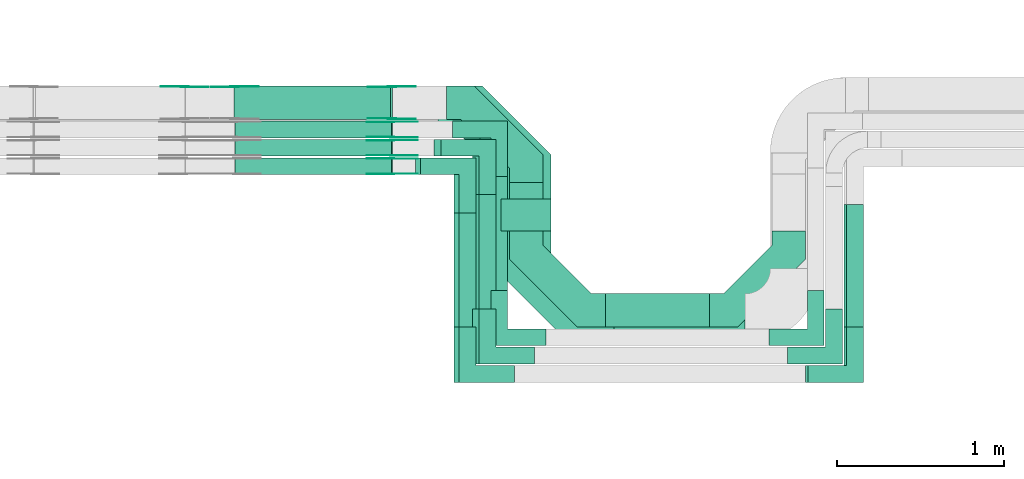
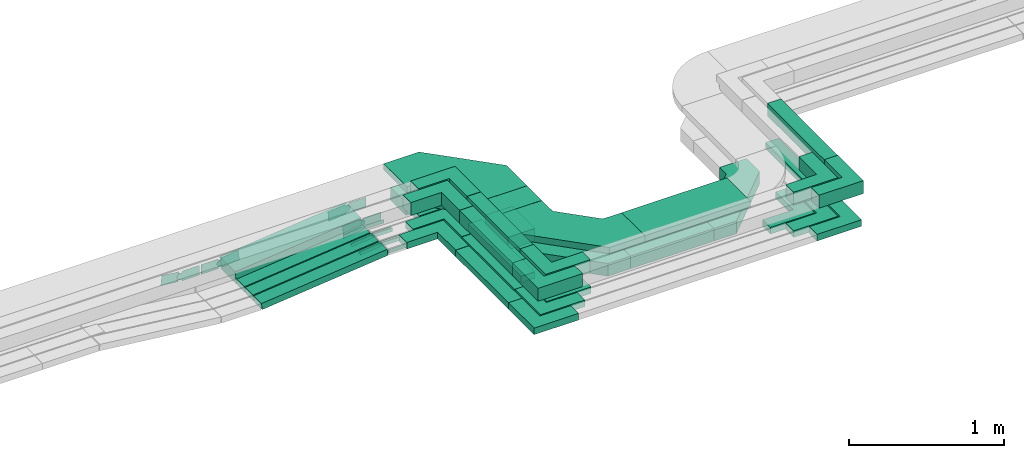
# One storey, part 19 of 32: 40 flow fittings, 15 flow segments.
"""IFC2X3 building model written with IfcOpenShell, lengths in millimetres."""

from ifc_helpers import new_model, entity, si_unit, converted_unit, derived_unit, direction, frame, frame_2d, origin, origin_2d_with_axis, place, context, subcontext, project, spatial, polyline, circle_curve, parameter, trimmed, segment, composite_curve, rectangle, outline, extrude, source, transform, mapped, material, type_object, type_shapes, element, save


model = new_model("IFC2X3")

# Units and contexts
model_context = context("Model", 3, precision=0.01, world=origin(), true_north=direction((6.12303176911189e-17, 1.0)))
body_context = subcontext(model_context, "Body", "Model", "MODEL_VIEW")
ifc_project = project(units=[si_unit("LENGTHUNIT", "METRE", prefix="MILLI"), si_unit("AREAUNIT", "SQUARE_METRE"), si_unit("VOLUMEUNIT", "CUBIC_METRE"), converted_unit("PLANEANGLEUNIT", "DEGREE", entity("IfcRatioMeasure", 0.0174532925199433), si_unit("PLANEANGLEUNIT", "RADIAN"), dimensions=[0, 0, 0, 0, 0, 0, 0]), si_unit("MASSUNIT", "GRAM", prefix="KILO"), derived_unit("MASSDENSITYUNIT", [(si_unit("MASSUNIT", "GRAM", prefix="KILO"), 1), (si_unit("LENGTHUNIT", "METRE"), -3)]), derived_unit("MOMENTOFINERTIAUNIT", [(si_unit("LENGTHUNIT", "METRE"), 4)]), si_unit("TIMEUNIT", "SECOND"), si_unit("FREQUENCYUNIT", "HERTZ"), si_unit("THERMODYNAMICTEMPERATUREUNIT", "DEGREE_CELSIUS"), derived_unit("THERMALTRANSMITTANCEUNIT", [(si_unit("MASSUNIT", "GRAM", prefix="KILO"), 1), (si_unit("THERMODYNAMICTEMPERATUREUNIT", "KELVIN"), -1), (si_unit("TIMEUNIT", "SECOND"), -3)]), derived_unit("VOLUMETRICFLOWRATEUNIT", [(si_unit("LENGTHUNIT", "METRE"), 3), (si_unit("TIMEUNIT", "SECOND"), -1)]), derived_unit("MASSFLOWRATEUNIT", [(si_unit("MASSUNIT", "GRAM", prefix="KILO"), 1), (si_unit("TIMEUNIT", "SECOND"), -1)]), derived_unit("ROTATIONALFREQUENCYUNIT", [(si_unit("TIMEUNIT", "SECOND"), -1)]), si_unit("ELECTRICCURRENTUNIT", "AMPERE"), si_unit("ELECTRICVOLTAGEUNIT", "VOLT"), si_unit("POWERUNIT", "WATT"), si_unit("FORCEUNIT", "NEWTON", prefix="KILO"), si_unit("ILLUMINANCEUNIT", "LUX"), si_unit("LUMINOUSFLUXUNIT", "LUMEN"), si_unit("LUMINOUSINTENSITYUNIT", "CANDELA"), derived_unit("USERDEFINED", [(si_unit("MASSUNIT", "GRAM", prefix="KILO"), -1), (si_unit("LENGTHUNIT", "METRE"), -2), (si_unit("TIMEUNIT", "SECOND"), 3), (si_unit("LUMINOUSFLUXUNIT", "LUMEN"), 1)]), derived_unit("LINEARVELOCITYUNIT", [(si_unit("LENGTHUNIT", "METRE"), 1), (si_unit("TIMEUNIT", "SECOND"), -1)]), si_unit("PRESSUREUNIT", "PASCAL"), derived_unit("USERDEFINED", [(si_unit("LENGTHUNIT", "METRE"), -2), (si_unit("MASSUNIT", "GRAM", prefix="KILO"), 1), (si_unit("TIMEUNIT", "SECOND"), -2)]), derived_unit("LINEARFORCEUNIT", [(si_unit("MASSUNIT", "GRAM", prefix="KILO"), 1), (si_unit("LENGTHUNIT", "METRE"), 1), (si_unit("TIMEUNIT", "SECOND"), -2), (si_unit("LENGTHUNIT", "METRE"), -1)]), derived_unit("PLANARFORCEUNIT", [(si_unit("MASSUNIT", "GRAM", prefix="KILO"), 1), (si_unit("LENGTHUNIT", "METRE"), 1), (si_unit("TIMEUNIT", "SECOND"), -2), (si_unit("LENGTHUNIT", "METRE"), -2)])], contexts=[model_context])

# Site, building, storey
site_placement = place(None, origin())
site = spatial("IfcSite", under=ifc_project, at=site_placement, CompositionType="ELEMENT")
building_placement = place(site_placement, origin())
building = spatial("IfcBuilding", under=site, at=building_placement, CompositionType="ELEMENT")
storey_placement = place(building_placement, frame((0.0, 0.0, 8100.0)))
storey = spatial("IfcBuildingStorey", under=building, at=storey_placement, CompositionType="ELEMENT", Elevation=8100.0)

# Flow segments
cable_carrier_segment_type = type_object("IfcCableCarrierSegmentType", PredefinedType="CABLETRAYSEGMENT")
flow_segment_1_placement = place(storey_placement, frame((42997.19, 9308.69, 2547.39)))
element("IfcFlowSegment", 1, at=flow_segment_1_placement, inside=storey, type_object=cable_carrier_segment_type, context=body_context, shape_type="SweptSolid", body=[
    extrude(rectangle(XDim=290.308950714313, YDim=200.000000000007, at=origin_2d_with_axis()), frame((100.0, 145.15, 0.0), z_axis=(0.0, 0.0, 1.0), x_axis=(0.0, -1.0, 0.0)), (0.0, 0.0, 1.0), 99.9999999999989),
])
flow_segment_2_placement = place(storey_placement, frame((42887.19, 8952.69, 2544.93)))
element("IfcFlowSegment", 2, at=flow_segment_2_placement, inside=storey, type_object=cable_carrier_segment_type, context=body_context, shape_type="SweptSolid", body=[
    extrude(rectangle(XDim=682.308950714327, YDim=99.9999999999946, at=origin_2d_with_axis()), frame((50.0, 341.15, 0.0), z_axis=(0.0, 0.0, 1.0), x_axis=(0.0, -1.0, 0.0)), (0.0, 0.0, 1.0), 50.0000000000016),
])
flow_segment_3_placement = place(storey_placement, frame((42777.19, 8842.69, 2546.32)))
element("IfcFlowSegment", 3, at=flow_segment_3_placement, inside=storey, type_object=cable_carrier_segment_type, context=body_context, shape_type="SweptSolid", body=[
    extrude(rectangle(XDim=682.308950714317, YDim=99.9999999999946, at=origin_2d_with_axis()), frame((50.0, 341.15, 0.0), z_axis=(0.0, 0.0, 1.0), x_axis=(0.0, -1.0, 0.0)), (0.0, 0.0, 1.0), 49.9999999999995),
])
flow_segment_4_placement = place(storey_placement, frame((42667.19, 8732.69, 2546.67)))
element("IfcFlowSegment", 4, at=flow_segment_4_placement, inside=storey, type_object=cable_carrier_segment_type, context=body_context, shape_type="SweptSolid", body=[
    extrude(rectangle(XDim=682.307504051767, YDim=99.9999999999946, at=origin_2d_with_axis()), frame((50.0, 341.15, 0.0), z_axis=(0.0, 0.0, 1.0), x_axis=(0.0, -1.0, 0.0)), (0.0, 0.0, 1.0), 50.0000000000016),
])
flow_segment_5_placement = place(storey_placement, frame((42697.19, 8732.69, 2799.28)))
element("IfcFlowSegment", 5, at=flow_segment_5_placement, inside=storey, type_object=cable_carrier_segment_type, context=body_context, shape_type="SweptSolid", body=[
    extrude(rectangle(XDim=682.307504051765, YDim=99.9999999999946, at=origin_2d_with_axis()), frame((50.0, 341.15, 0.0), z_axis=(0.0, 0.0, 1.0), x_axis=(0.0, -1.0, 0.0)), (0.0, 0.0, 1.0), 99.9999999999989),
])
flow_segment_6_placement = place(storey_placement, frame((42817.19, 8842.69, 2800.01)))
element("IfcFlowSegment", 6, at=flow_segment_6_placement, inside=storey, type_object=cable_carrier_segment_type, context=body_context, shape_type="SweptSolid", body=[
    extrude(rectangle(XDim=682.308950714305, YDim=99.9999999999946, at=origin_2d_with_axis()), frame((50.0, 341.15, 0.0), z_axis=(0.0, 0.0, 1.0), x_axis=(0.0, -1.0, 0.0)), (0.0, 0.0, 1.0), 99.9999999999989),
])
flow_segment_7_placement = place(storey_placement, frame((42947.19, 9308.69, 2800.02)))
element("IfcFlowSegment", 7, at=flow_segment_7_placement, inside=storey, type_object=cable_carrier_segment_type, context=body_context, shape_type="SweptSolid", body=[
    extrude(rectangle(XDim=190.308950714306, YDim=300.000000000001, at=origin_2d_with_axis()), frame((150.0, 95.15, 0.0), z_axis=(0.0, 0.0, 1.0), x_axis=(0.0, -1.0, 0.0)), (0.0, 0.0, 1.0), 50.0000000000016),
])
flow_segment_8_placement = place(storey_placement, frame((43573.19, 8732.69, 2547.39)))
element("IfcFlowSegment", 8, at=flow_segment_8_placement, inside=storey, type_object=cable_carrier_segment_type, context=body_context, shape_type="SweptSolid", body=[
    extrude(rectangle(XDim=620.201042721613, YDim=200.0, at=origin_2d_with_axis()), frame((310.1, 100.0, 0.0)), (0.0, 0.0, 1.0), 99.9999999999989),
])
flow_segment_9_placement = place(storey_placement, frame((43623.19, 8632.69, 2800.02)))
element("IfcFlowSegment", 9, at=flow_segment_9_placement, inside=storey, type_object=cable_carrier_segment_type, context=body_context, shape_type="SweptSolid", body=[
    extrude(rectangle(XDim=783.533040751397, YDim=300.000000000001, at=origin_2d_with_axis()), frame((391.77, 150.0, 0.0)), (0.0, 0.0, 1.0), 50.0000000000038),
])
flow_segment_10_placement = place(storey_placement, frame((45014.9, 8732.69, 2799.28)))
element("IfcFlowSegment", 10, at=flow_segment_10_placement, inside=storey, type_object=cable_carrier_segment_type, context=body_context, shape_type="SweptSolid", body=[
    extrude(rectangle(XDim=732.30962512756, YDim=100.000000000006, at=origin_2d_with_axis()), frame((50.0, 366.15, 0.0), z_axis=(4.69987074325191e-07, 0.0, 1.0), x_axis=(0.0, -1.0, 0.0)), (0.0, 0.0, 1.0), 100.000000000001),
])
flow_segment_11_placement = place(storey_placement, frame((44999.9, 8732.69, 2546.67)))
element("IfcFlowSegment", 11, at=flow_segment_11_placement, inside=storey, type_object=cable_carrier_segment_type, context=body_context, shape_type="SweptSolid", body=[
    extrude(rectangle(XDim=732.309800463485, YDim=99.9999999999946, at=origin_2d_with_axis()), frame((50.0, 366.15, 0.0), z_axis=(0.0, 0.0, 1.0), x_axis=(0.0, 1.0, 0.0)), (0.0, 0.0, 1.0), 50.0000000000016),
])
flow_segment_12_placement = place(storey_placement, frame((41357.07, 9645.0, 2447.08)))
element("IfcFlowSegment", 12, at=flow_segment_12_placement, inside=storey, type_object=cable_carrier_segment_type, context=body_context, shape_type="SweptSolid", body=[
    extrude(rectangle(XDim=49.999999999999, YDim=100.000000000001, at=origin_2d_with_axis()), frame((2.64, 50.0, 24.86), z_axis=(0.994388913179111, 0.0, 0.105786054593537), x_axis=(-0.105786054593537, 0.0, 0.994388913179111)), (0.0, 0.0, 1.0), 940.227757215781),
])
flow_segment_13_placement = place(storey_placement, frame((41357.1, 9755.0, 2446.73)))
element("IfcFlowSegment", 13, at=flow_segment_13_placement, inside=storey, type_object=cable_carrier_segment_type, context=body_context, shape_type="SweptSolid", body=[
    extrude(rectangle(XDim=49.9999999999999, YDim=99.9999999999989, at=origin_2d_with_axis()), frame((2.64, 50.0, 24.86), z_axis=(0.994388913179093, 0.0, 0.105786054593709), x_axis=(-0.105786054593709, 0.0, 0.994388913179093)), (0.0, 0.0, 1.0), 940.190697975519),
])
flow_segment_14_placement = place(storey_placement, frame((41357.07, 9865.0, 2445.39)))
element("IfcFlowSegment", 14, at=flow_segment_14_placement, inside=storey, type_object=cable_carrier_segment_type, context=body_context, shape_type="SweptSolid", body=[
    extrude(rectangle(XDim=49.9999999999999, YDim=99.9999999999989, at=origin_2d_with_axis()), frame((2.64, 50.0, 24.86), z_axis=(0.994388913179093, 0.0, 0.105786054593709), x_axis=(-0.105786054593709, 0.0, 0.994388913179093)), (0.0, 0.0, 1.0), 940.407341948837),
])
flow_segment_15_placement = place(storey_placement, frame((41351.7, 9975.0, 2447.8)))
element("IfcFlowSegment", 15, at=flow_segment_15_placement, inside=storey, type_object=cable_carrier_segment_type, context=body_context, shape_type="SweptSolid", body=[
    extrude(rectangle(XDim=99.999999999998, YDim=199.999999999998, at=origin_2d_with_axis()), frame((5.29, 100.0, 49.72), z_axis=(0.994388913179111, 0.0, 0.105786054593537), x_axis=(-0.105786054593537, 0.0, 0.994388913179111)), (0.0, 0.0, 1.0), 940.304512766153),
])

# Flow fittings
ifc_material_1 = material()
cable_carrier_fitting_type_1 = type_object("IfcCableCarrierFittingType", Name="470_DKC_G5_Sheet horizontal bend:-", PredefinedType="NOTDEFINED", material=ifc_material_1)
shared_shape_1 = source(origin(), body_context, "Body", "SweptSolid", [
    extrude(outline(polyline([(-269.5, -306.5), (-102.08, -306.5), (306.5, 102.08), (306.5, 269.5), (106.5, 269.5), (106.5, 184.92), (-184.92, -106.5), (-269.5, -106.5), (-269.5, -306.5)])), frame((-206.5, 206.5, -50.0)), (0.0, 0.0, 1.0), 100.0),
])
type_shapes(cable_carrier_fitting_type_1, [shared_shape_1])
flow_fitting_1_placement = place(storey_placement, frame((43097.19, 8832.69, 2597.39), z_axis=(0.0, 0.0, 1.0), x_axis=(0.0, -1.0, 0.0)))
element("IfcFlowFitting", 16, at=flow_fitting_1_placement, inside=storey, type_object=cable_carrier_fitting_type_1, material=ifc_material_1, Name="470_DKC_G5_Sheet horizontal bend:-", ObjectType="470_DKC_G5_Sheet horizontal bend:-", context=body_context, shape_type="MappedRepresentation", body=[
    mapped(shared_shape_1, transform((0.0, 0.0, 0.0), scale=1.0)),
])
flow_fitting_2_placement = place(storey_placement, frame((44669.39, 8832.69, 2597.39)))
element("IfcFlowFitting", 17, at=flow_fitting_2_placement, inside=storey, type_object=cable_carrier_fitting_type_1, material=ifc_material_1, Name="470_DKC_G5_Sheet horizontal bend:-", ObjectType="470_DKC_G5_Sheet horizontal bend:-", context=body_context, shape_type="MappedRepresentation", body=[
    mapped(shared_shape_1, transform((0.0, 0.0, 0.0), scale=1.0)),
])
flow_fitting_3_placement = place(storey_placement, frame((43097.19, 10075.0, 2597.39), z_axis=(0.0, 0.0, 1.0), x_axis=(0.0, 1.0, 0.0)))
element("IfcFlowFitting", 18, at=flow_fitting_3_placement, inside=storey, type_object=cable_carrier_fitting_type_1, material=ifc_material_1, Name="470_DKC_G5_Sheet horizontal bend:-", ObjectType="470_DKC_G5_Sheet horizontal bend:-", context=body_context, shape_type="MappedRepresentation", body=[
    mapped(shared_shape_1, transform((0.0, 0.0, 0.0), scale=1.0)),
])
cable_carrier_fitting_type_2 = type_object("IfcCableCarrierFittingType", Name="470_DKC_F5_Mesh horizontal angle:At right angles", PredefinedType="NOTDEFINED", material=ifc_material_1)
shared_shape_2 = source(origin(), body_context, "Body", "SweptSolid", [
    extrude(outline(polyline([(-143.33, -143.33), (186.67, -143.33), (186.67, -43.33), (-43.33, -43.33), (-43.33, 186.67), (-143.33, 186.67), (-143.33, -143.33)])), frame((-93.33, 93.33, -25.0), z_axis=(0.0, 0.0, 1.0), x_axis=(0.0, 1.0, 0.0)), (0.0, 0.0, 1.0), 51.9999999999999),
])
type_shapes(cable_carrier_fitting_type_2, [shared_shape_2])
for number, where, z_axis, x_axis, name in (
    (19, (42937.19, 8672.69, 2569.93), (0.0, 0.0, 1.0), (0.0, -1.0, 0.0), "470_DKC_F5_Mesh horizontal angle:At right angles"),
    (20, (42827.19, 8562.69, 2571.32), (0.0, 0.0, 1.0), (0.0, -1.0, 0.0), "470_DKC_F5_Mesh horizontal angle:At right angles"),
    (21, (42717.19, 8452.69, 2571.67), (0.0, 0.0, 1.0), (0.0, -1.0, 0.0), "470_DKC_F5_Mesh horizontal angle:At right angles"),
):
    element("IfcFlowFitting", number, at=place(storey_placement, frame(where, z_axis=z_axis, x_axis=x_axis)), inside=storey, type_object=cable_carrier_fitting_type_2, material=ifc_material_1, Name=name, ObjectType="470_DKC_F5_Mesh horizontal angle:At right angles", context=body_context, shape_type="MappedRepresentation", body=[
        mapped(shared_shape_2, transform((0.0, 0.0, 0.0), scale=1.0)),
    ])
for number, where, name in (
    (22, (44829.39, 8672.69, 2569.93), "470_DKC_F5_Mesh horizontal angle:At right angles"),
    (23, (45049.9, 8452.69, 2571.67), "470_DKC_F5_Mesh horizontal angle:At right angles"),
    (24, (44939.39, 8562.69, 2571.32), "470_DKC_F5_Mesh horizontal angle:At right angles"),
):
    element("IfcFlowFitting", number, at=place(storey_placement, frame(where)), inside=storey, type_object=cable_carrier_fitting_type_2, material=ifc_material_1, Name=name, ObjectType="470_DKC_F5_Mesh horizontal angle:At right angles", context=body_context, shape_type="MappedRepresentation", body=[
        mapped(shared_shape_2, transform((0.0, 0.0, 0.0), scale=1.0)),
    ])
for number, where, z_axis, x_axis, name in (
    (25, (42717.19, 9695.0, 2571.67), (0.0, 0.0, 1.0), (0.0, 1.0, 0.0), "470_DKC_F5_Mesh horizontal angle:At right angles"),
    (26, (42827.19, 9805.0, 2571.32), (0.0, 0.0, 1.0), (0.0, 1.0, 0.0), "470_DKC_F5_Mesh horizontal angle:At right angles"),
    (27, (42937.19, 9915.0, 2569.93), (0.00011888167183542, 0.0, 0.999999992933574), (0.0, 1.0, 0.0), "470_DKC_F5_Mesh horizontal angle:At right angles"),
):
    element("IfcFlowFitting", number, at=place(storey_placement, frame(where, z_axis=z_axis, x_axis=x_axis)), inside=storey, type_object=cable_carrier_fitting_type_2, material=ifc_material_1, Name=name, ObjectType="470_DKC_F5_Mesh horizontal angle:At right angles", context=body_context, shape_type="MappedRepresentation", body=[
        mapped(shared_shape_2, transform((0.0, 0.0, 0.0), scale=1.0)),
    ])
cable_carrier_fitting_type_3 = type_object("IfcCableCarrierFittingType", Name="470_DKC_F5_Mesh horizontal angle:At right angles", PredefinedType="NOTDEFINED", material=ifc_material_1)
shared_shape_3 = source(origin(), body_context, "Body", "SweptSolid", [
    extrude(outline(polyline([(-143.33, -143.33), (186.67, -143.33), (186.67, -43.33), (-43.33, -43.33), (-43.33, 186.67), (-143.33, 186.67), (-143.33, -143.33)])), frame((-93.33, 93.33, -50.0), z_axis=(0.0, 0.0, 1.0), x_axis=(0.0, 1.0, 0.0)), (0.0, 0.0, 1.0), 102.0),
])
type_shapes(cable_carrier_fitting_type_3, [shared_shape_3])
for number, where, z_axis, x_axis, name in (
    (28, (42747.19, 8452.69, 2849.28), (0.0, 0.0, 1.0), (0.0, -1.0, 0.0), "470_DKC_F5_Mesh horizontal angle:At right angles"),
    (29, (42867.19, 8562.69, 2850.01), (0.0, 0.0, 1.0), (0.0, -1.0, 0.0), "470_DKC_F5_Mesh horizontal angle:At right angles"),
):
    element("IfcFlowFitting", number, at=place(storey_placement, frame(where, z_axis=z_axis, x_axis=x_axis)), inside=storey, type_object=cable_carrier_fitting_type_3, material=ifc_material_1, Name=name, ObjectType="470_DKC_F5_Mesh horizontal angle:At right angles", context=body_context, shape_type="MappedRepresentation", body=[
        mapped(shared_shape_3, transform((0.0, 0.0, 0.0), scale=1.0)),
    ])
for number, where, name in (
    (30, (44939.39, 8562.69, 2850.01), "470_DKC_F5_Mesh horizontal angle:At right angles"),
    (31, (45064.9, 8452.69, 2849.28), "470_DKC_F5_Mesh horizontal angle:At right angles"),
):
    element("IfcFlowFitting", number, at=place(storey_placement, frame(where)), inside=storey, type_object=cable_carrier_fitting_type_3, material=ifc_material_1, Name=name, ObjectType="470_DKC_F5_Mesh horizontal angle:At right angles", context=body_context, shape_type="MappedRepresentation", body=[
        mapped(shared_shape_3, transform((0.0, 0.0, 0.0), scale=1.0)),
    ])
for number, where, z_axis, x_axis, name in (
    (32, (42747.19, 9695.0, 2849.28), (0.0, 0.0, 1.0), (0.0, 1.0, 0.0), "470_DKC_F5_Mesh horizontal angle:At right angles"),
    (33, (42867.19, 9805.0, 2850.01), (0.0, 0.0, 1.0), (0.0, 1.0, 0.0), "470_DKC_F5_Mesh horizontal angle:At right angles"),
):
    element("IfcFlowFitting", number, at=place(storey_placement, frame(where, z_axis=z_axis, x_axis=x_axis)), inside=storey, type_object=cable_carrier_fitting_type_3, material=ifc_material_1, Name=name, ObjectType="470_DKC_F5_Mesh horizontal angle:At right angles", context=body_context, shape_type="MappedRepresentation", body=[
        mapped(shared_shape_3, transform((0.0, 0.0, 0.0), scale=1.0)),
    ])
cable_carrier_fitting_type_4 = type_object("IfcCableCarrierFittingType", Name="470_DKC_G5_Sheet horizontal bend:-", PredefinedType="NOTDEFINED", material=ifc_material_1)
shared_shape_4 = source(origin(), body_context, "Body", "SweptSolid", [
    extrude(outline(polyline([(-313.25, -362.75), (-50.12, -362.75), (362.75, 50.12), (362.75, 313.25), (62.75, 313.25), (62.75, 174.38), (-174.38, -62.75), (-313.25, -62.75), (-313.25, -362.75)])), frame((-212.75, 212.75, -25.0)), (0.0, 0.0, 1.0), 50.0000000000003),
])
type_shapes(cable_carrier_fitting_type_4, [shared_shape_4])
for number, where, z_axis, x_axis, name in (
    (34, (43097.19, 10025.0, 2825.02), (0.0, 0.0, 1.0), (0.0, 1.0, 0.0), "470_DKC_G5_Sheet horizontal bend:-"),
    (35, (43097.19, 8782.69, 2825.02), (0.0, 0.0, 1.0), (0.0, -1.0, 0.0), "470_DKC_G5_Sheet horizontal bend:-"),
):
    element("IfcFlowFitting", number, at=place(storey_placement, frame(where, z_axis=z_axis, x_axis=x_axis)), inside=storey, type_object=cable_carrier_fitting_type_4, material=ifc_material_1, Name=name, ObjectType="470_DKC_G5_Sheet horizontal bend:-", context=body_context, shape_type="MappedRepresentation", body=[
        mapped(shared_shape_4, transform((0.0, 0.0, 0.0), scale=1.0)),
    ])
ifc_material_2 = material(Name="G")
cable_carrier_fitting_type_5 = type_object("IfcCableCarrierFittingType", PredefinedType="NOTDEFINED", material=ifc_material_2)
shared_shape_5 = source(origin(), body_context, "Body", "SweptSolid", [
    extrude(outline(composite_curve([segment(trimmed(circle_curve(frame_2d((-44.59, 0.0), x_axis=(1.0, 0.0)), 12.5), [parameter(90.0000000000007)], [parameter(270.0)], True, "PARAMETER"), True, "CONTINUOUS"), segment(polyline([(-44.59, -12.5), (-33.09, -12.5)]), True, "CONTINUOUS"), segment(polyline([(-33.09, -12.5), (-31.23, -14.5)]), True, "CONTINUOUS"), segment(polyline([(-31.23, -14.5), (108.91, -14.5)]), True, "CONTINUOUS"), segment(polyline([(108.91, -14.5), (108.91, 14.5)]), True, "CONTINUOUS"), segment(polyline([(108.91, 14.5), (-31.23, 14.5)]), True, "CONTINUOUS"), segment(polyline([(-31.23, 14.5), (-33.09, 12.5)]), True, "CONTINUOUS"), segment(polyline([(-33.09, 12.5), (-44.59, 12.5)]), True, "CONTINUOUS")], self_intersect=False)), frame((44.59, 0.0, 0.0), z_axis=(0.0, 0.0, -1.0), x_axis=(1.0, 0.0, 0.0)), (0.0, 0.0, -1.0), 2.0),
])
type_shapes(cable_carrier_fitting_type_5, [shared_shape_5])
flow_fitting_4_placement = place(storey_placement, frame((42297.19, 9649.54, 2571.67), z_axis=(0.0, -1.0, 0.0), x_axis=(-0.994388913179106, 0.0, -0.105786054593584)))
element("IfcFlowFitting", 36, at=flow_fitting_4_placement, inside=storey, type_object=cable_carrier_fitting_type_5, material=ifc_material_2, context=body_context, shape_type="MappedRepresentation", body=[
    mapped(shared_shape_5, transform((0.0, 0.0, 0.0), scale=1.0)),
])
cable_carrier_fitting_type_6 = type_object("IfcCableCarrierFittingType", PredefinedType="NOTDEFINED", material=ifc_material_2)
type_shapes(cable_carrier_fitting_type_6, [shared_shape_5])
flow_fitting_5_placement = place(storey_placement, frame((42297.19, 9738.46, 2571.67), z_axis=(0.0, 1.0, 0.0), x_axis=(1.0, 0.0, 0.0)))
element("IfcFlowFitting", 37, at=flow_fitting_5_placement, inside=storey, type_object=cable_carrier_fitting_type_6, material=ifc_material_2, context=body_context, shape_type="MappedRepresentation", body=[
    mapped(shared_shape_5, transform((0.0, 0.0, 0.0), scale=1.0)),
])
flow_fitting_6_placement = place(storey_placement, frame((42297.19, 9850.46, 2571.32), z_axis=(0.0, 1.0, 0.0), x_axis=(1.0, 0.0, 0.0)))
element("IfcFlowFitting", 38, at=flow_fitting_6_placement, inside=storey, type_object=cable_carrier_fitting_type_5, material=ifc_material_2, context=body_context, shape_type="MappedRepresentation", body=[
    mapped(shared_shape_5, transform((0.0, 0.0, 0.0), scale=1.0)),
])
flow_fitting_7_placement = place(storey_placement, frame((42297.19, 9761.54, 2571.32), z_axis=(0.0, -1.0, 0.0), x_axis=(-0.994388913179106, 0.0, -0.105786054593578)))
element("IfcFlowFitting", 39, at=flow_fitting_7_placement, inside=storey, type_object=cable_carrier_fitting_type_6, material=ifc_material_2, context=body_context, shape_type="MappedRepresentation", body=[
    mapped(shared_shape_5, transform((0.0, 0.0, 0.0), scale=1.0)),
])
flow_fitting_8_placement = place(storey_placement, frame((42297.37, 9960.46, 2570.0), z_axis=(0.0, 1.0, 0.0), x_axis=(0.999999992933574, 0.0, -0.000118881671840432)))
element("IfcFlowFitting", 40, at=flow_fitting_8_placement, inside=storey, type_object=cable_carrier_fitting_type_5, material=ifc_material_2, context=body_context, shape_type="MappedRepresentation", body=[
    mapped(shared_shape_5, transform((0.0, 0.0, 0.0), scale=1.0)),
])
flow_fitting_9_placement = place(storey_placement, frame((42297.37, 9871.54, 2570.0), z_axis=(0.0, -1.0, 0.0), x_axis=(-0.994388913179107, 0.0, -0.105786054593577)))
element("IfcFlowFitting", 41, at=flow_fitting_9_placement, inside=storey, type_object=cable_carrier_fitting_type_6, material=ifc_material_2, context=body_context, shape_type="MappedRepresentation", body=[
    mapped(shared_shape_5, transform((0.0, 0.0, 0.0), scale=1.0)),
])
cable_carrier_fitting_type_7 = type_object("IfcCableCarrierFittingType", PredefinedType="NOTDEFINED", material=ifc_material_2)
shared_shape_6 = source(origin(), body_context, "Body", "SweptSolid", [
    extrude(outline(composite_curve([segment(trimmed(circle_curve(frame_2d((-44.59, 0.0), x_axis=(1.0, 0.0)), 12.5), [parameter(90.0000000000007)], [parameter(270.0)], True, "PARAMETER"), True, "CONTINUOUS"), segment(polyline([(-44.59, -12.5), (-33.09, -12.5)]), True, "CONTINUOUS"), segment(polyline([(-33.09, -12.5), (-31.23, -14.5)]), True, "CONTINUOUS"), segment(polyline([(-31.23, -14.5), (108.91, -14.5)]), True, "CONTINUOUS"), segment(polyline([(108.91, -14.5), (108.91, 14.5)]), True, "CONTINUOUS"), segment(polyline([(108.91, 14.5), (-31.23, 14.5)]), True, "CONTINUOUS"), segment(polyline([(-31.23, 14.5), (-33.09, 12.5)]), True, "CONTINUOUS"), segment(polyline([(-33.09, 12.5), (-44.59, 12.5)]), True, "CONTINUOUS")], self_intersect=False)), frame((44.59, 0.0, 0.0)), (0.0, 0.0, 1.0), 2.0),
])
type_shapes(cable_carrier_fitting_type_7, [shared_shape_6])
flow_fitting_10_placement = place(storey_placement, frame((42297.19, 9740.46, 2571.67), z_axis=(0.0, 1.0, 0.0), x_axis=(-0.994388913179106, 0.0, -0.105786054593584)))
element("IfcFlowFitting", 42, at=flow_fitting_10_placement, inside=storey, type_object=cable_carrier_fitting_type_7, material=ifc_material_2, context=body_context, shape_type="MappedRepresentation", body=[
    mapped(shared_shape_6, transform((0.0, 0.0, 0.0), scale=1.0)),
])
cable_carrier_fitting_type_8 = type_object("IfcCableCarrierFittingType", PredefinedType="NOTDEFINED", material=ifc_material_2)
type_shapes(cable_carrier_fitting_type_8, [shared_shape_6])
flow_fitting_11_placement = place(storey_placement, frame((42297.19, 9651.54, 2571.67), z_axis=(0.0, -1.0, 0.0), x_axis=(1.0, 0.0, 0.0)))
element("IfcFlowFitting", 43, at=flow_fitting_11_placement, inside=storey, type_object=cable_carrier_fitting_type_8, material=ifc_material_2, context=body_context, shape_type="MappedRepresentation", body=[
    mapped(shared_shape_6, transform((0.0, 0.0, 0.0), scale=1.0)),
])
flow_fitting_12_placement = place(storey_placement, frame((42297.19, 9759.54, 2571.32), z_axis=(0.0, -1.0, 0.0), x_axis=(1.0, 0.0, 0.0)))
element("IfcFlowFitting", 44, at=flow_fitting_12_placement, inside=storey, type_object=cable_carrier_fitting_type_7, material=ifc_material_2, context=body_context, shape_type="MappedRepresentation", body=[
    mapped(shared_shape_6, transform((0.0, 0.0, 0.0), scale=1.0)),
])
flow_fitting_13_placement = place(storey_placement, frame((42297.19, 9848.46, 2571.32), z_axis=(0.0, 1.0, 0.0), x_axis=(-0.994388913179106, 0.0, -0.105786054593578)))
element("IfcFlowFitting", 45, at=flow_fitting_13_placement, inside=storey, type_object=cable_carrier_fitting_type_8, material=ifc_material_2, context=body_context, shape_type="MappedRepresentation", body=[
    mapped(shared_shape_6, transform((0.0, 0.0, 0.0), scale=1.0)),
])
flow_fitting_14_placement = place(storey_placement, frame((42297.37, 9869.54, 2570.0), z_axis=(0.0, -1.0, 0.0), x_axis=(0.999999992933574, 0.0, -0.000118881671840432)))
element("IfcFlowFitting", 46, at=flow_fitting_14_placement, inside=storey, type_object=cable_carrier_fitting_type_7, material=ifc_material_2, context=body_context, shape_type="MappedRepresentation", body=[
    mapped(shared_shape_6, transform((0.0, 0.0, 0.0), scale=1.0)),
])
flow_fitting_15_placement = place(storey_placement, frame((42297.37, 9958.46, 2570.0), z_axis=(0.0, 1.0, 0.0), x_axis=(-0.994388913179107, 0.0, -0.105786054593577)))
element("IfcFlowFitting", 47, at=flow_fitting_15_placement, inside=storey, type_object=cable_carrier_fitting_type_8, material=ifc_material_2, context=body_context, shape_type="MappedRepresentation", body=[
    mapped(shared_shape_6, transform((0.0, 0.0, 0.0), scale=1.0)),
])
cable_carrier_fitting_type_9 = type_object("IfcCableCarrierFittingType", PredefinedType="NOTDEFINED", material=ifc_material_2)
shared_shape_7 = source(origin(), body_context, "Body", "SweptSolid", [
    extrude(outline(composite_curve([segment(trimmed(circle_curve(frame_2d((-41.47, 0.0), x_axis=(1.0, 0.0)), 25.0), [parameter(90.0000000000007)], [parameter(270.0)], True, "PARAMETER"), True, "CONTINUOUS"), segment(polyline([(-41.47, -25.0), (-29.97, -25.0)]), True, "CONTINUOUS"), segment(polyline([(-29.97, -25.0), (-28.1, -38.5)]), True, "CONTINUOUS"), segment(polyline([(-28.1, -38.5), (99.53, -38.5)]), True, "CONTINUOUS"), segment(polyline([(99.53, -38.5), (99.53, 38.5)]), True, "CONTINUOUS"), segment(polyline([(99.53, 38.5), (-28.1, 38.5)]), True, "CONTINUOUS"), segment(polyline([(-28.1, 38.5), (-29.97, 25.0)]), True, "CONTINUOUS"), segment(polyline([(-29.97, 25.0), (-41.47, 25.0)]), True, "CONTINUOUS")], self_intersect=False)), frame((41.47, 0.0, 0.0), z_axis=(0.0, 0.0, -1.0), x_axis=(1.0, 0.0, 0.0)), (0.0, 0.0, -1.0), 2.0),
])
type_shapes(cable_carrier_fitting_type_9, [shared_shape_7])
flow_fitting_16_placement = place(storey_placement, frame((41353.15, 10168.46, 2497.11), z_axis=(0.0, 1.0, 0.0), x_axis=(-1.0, 0.0, 0.0)))
element("IfcFlowFitting", 48, at=flow_fitting_16_placement, inside=storey, type_object=cable_carrier_fitting_type_9, material=ifc_material_2, context=body_context, shape_type="MappedRepresentation", body=[
    mapped(shared_shape_7, transform((0.0, 0.0, 0.0), scale=1.0)),
])
cable_carrier_fitting_type_10 = type_object("IfcCableCarrierFittingType", PredefinedType="NOTDEFINED", material=ifc_material_2)
type_shapes(cable_carrier_fitting_type_10, [shared_shape_7])
for number, where, z_axis, x_axis in (
    (49, (41055.81, 10170.46, 2497.11), (0.0, 1.0, 0.0), (-0.993961132894515, 0.0, 0.10973270385374)),
    (50, (42295.86, 10170.46, 2597.39), (0.0, 1.0, 0.0), (1.0, 0.0, 0.0)),
):
    element("IfcFlowFitting", number, at=place(storey_placement, frame(where, z_axis=z_axis, x_axis=x_axis)), inside=storey, type_object=cable_carrier_fitting_type_10, material=ifc_material_2, context=body_context, shape_type="MappedRepresentation", body=[
        mapped(shared_shape_7, transform((0.0, 0.0, 0.0), scale=1.0)),
    ])
flow_fitting_17_placement = place(storey_placement, frame((42295.86, 9981.54, 2597.39), z_axis=(0.0, -1.0, 0.0), x_axis=(-0.994388913179106, 0.0, -0.105786054593579)))
element("IfcFlowFitting", 51, at=flow_fitting_17_placement, inside=storey, type_object=cable_carrier_fitting_type_9, material=ifc_material_2, context=body_context, shape_type="MappedRepresentation", body=[
    mapped(shared_shape_7, transform((0.0, 0.0, 0.0), scale=1.0)),
])
cable_carrier_fitting_type_11 = type_object("IfcCableCarrierFittingType", PredefinedType="NOTDEFINED", material=ifc_material_2)
shared_shape_8 = source(origin(), body_context, "Body", "SweptSolid", [
    extrude(outline(composite_curve([segment(trimmed(circle_curve(frame_2d((-41.47, 0.0), x_axis=(1.0, 0.0)), 25.0), [parameter(90.0000000000007)], [parameter(270.0)], True, "PARAMETER"), True, "CONTINUOUS"), segment(polyline([(-41.47, -25.0), (-29.97, -25.0)]), True, "CONTINUOUS"), segment(polyline([(-29.97, -25.0), (-28.1, -38.5)]), True, "CONTINUOUS"), segment(polyline([(-28.1, -38.5), (99.53, -38.5)]), True, "CONTINUOUS"), segment(polyline([(99.53, -38.5), (99.53, 38.5)]), True, "CONTINUOUS"), segment(polyline([(99.53, 38.5), (-28.1, 38.5)]), True, "CONTINUOUS"), segment(polyline([(-28.1, 38.5), (-29.97, 25.0)]), True, "CONTINUOUS"), segment(polyline([(-29.97, 25.0), (-41.47, 25.0)]), True, "CONTINUOUS")], self_intersect=False)), frame((41.47, 0.0, 0.0)), (0.0, 0.0, 1.0), 2.0),
])
type_shapes(cable_carrier_fitting_type_11, [shared_shape_8])
flow_fitting_18_placement = place(storey_placement, frame((41353.15, 10170.46, 2497.11), z_axis=(0.0, 1.0, 0.0), x_axis=(0.994388913179106, 0.0, 0.105786054593584)))
element("IfcFlowFitting", 52, at=flow_fitting_18_placement, inside=storey, type_object=cable_carrier_fitting_type_11, material=ifc_material_2, context=body_context, shape_type="MappedRepresentation", body=[
    mapped(shared_shape_8, transform((0.0, 0.0, 0.0), scale=1.0)),
])
cable_carrier_fitting_type_12 = type_object("IfcCableCarrierFittingType", PredefinedType="NOTDEFINED", material=ifc_material_2)
type_shapes(cable_carrier_fitting_type_12, [shared_shape_8])
flow_fitting_19_placement = place(storey_placement, frame((41055.81, 10168.46, 2497.11), z_axis=(0.0, 1.0, 0.0), x_axis=(1.0, 0.0, 0.0)))
element("IfcFlowFitting", 53, at=flow_fitting_19_placement, inside=storey, type_object=cable_carrier_fitting_type_12, material=ifc_material_2, context=body_context, shape_type="MappedRepresentation", body=[
    mapped(shared_shape_8, transform((0.0, 0.0, 0.0), scale=1.0)),
])
flow_fitting_20_placement = place(storey_placement, frame((42295.86, 9979.54, 2597.39), z_axis=(0.0, -1.0, 0.0), x_axis=(1.0, 0.0, 0.0)))
element("IfcFlowFitting", 54, at=flow_fitting_20_placement, inside=storey, type_object=cable_carrier_fitting_type_11, material=ifc_material_2, context=body_context, shape_type="MappedRepresentation", body=[
    mapped(shared_shape_8, transform((0.0, 0.0, 0.0), scale=1.0)),
])
flow_fitting_21_placement = place(storey_placement, frame((42295.86, 10168.46, 2597.39), z_axis=(0.0, 1.0, 0.0), x_axis=(-0.994388913179106, 0.0, -0.105786054593579)))
element("IfcFlowFitting", 55, at=flow_fitting_21_placement, inside=storey, type_object=cable_carrier_fitting_type_12, material=ifc_material_2, context=body_context, shape_type="MappedRepresentation", body=[
    mapped(shared_shape_8, transform((0.0, 0.0, 0.0), scale=1.0)),
])

save(model, "model.ifc")
